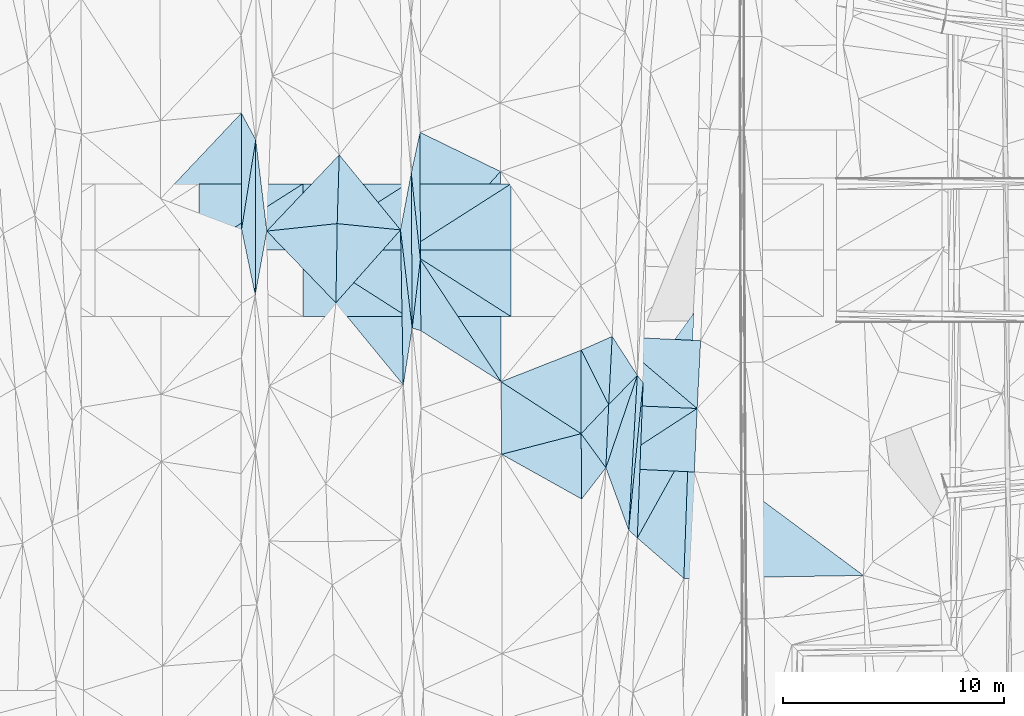
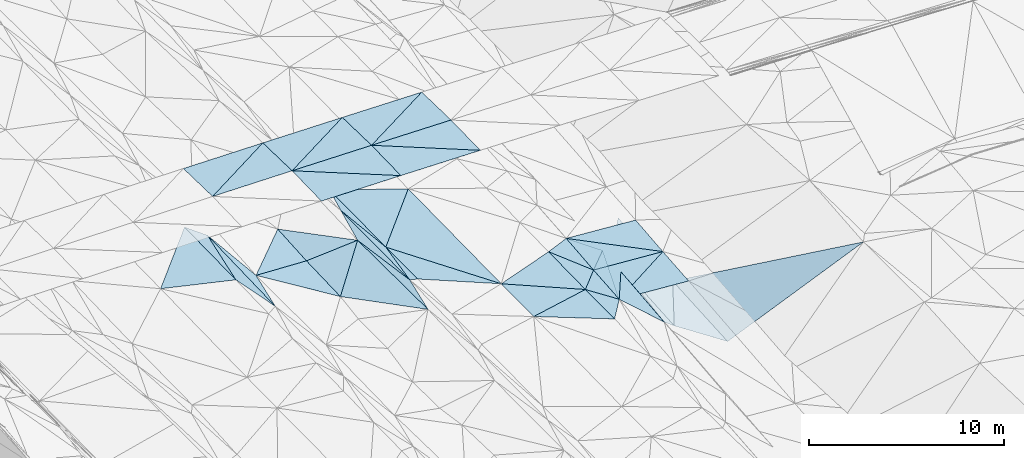
# One storey, part 95 of 275: 47 plates.
"""IFC2X3 building model written with IfcOpenShell, lengths in millimetres."""

from ifc_helpers import new_model, si_unit, frame, origin_with_axes, place, context, subcontext, project, spatial, polyline, outline, extrude, material, type_object, element, save


model = new_model("IFC2X3")

# Units and contexts
model_context = context("Model", 3, precision=1e-05, world=origin_with_axes())
body_context = subcontext(model_context, "Body", "Model", "MODEL_VIEW")
ifc_project = project(units=[si_unit("LENGTHUNIT", "METRE", prefix="MILLI"), si_unit("AREAUNIT", "SQUARE_METRE"), si_unit("VOLUMEUNIT", "CUBIC_METRE"), si_unit("MASSUNIT", "GRAM", prefix="KILO"), si_unit("TIMEUNIT", "SECOND"), si_unit("PLANEANGLEUNIT", "RADIAN"), si_unit("SOLIDANGLEUNIT", "STERADIAN"), si_unit("THERMODYNAMICTEMPERATUREUNIT", "DEGREE_CELSIUS"), si_unit("LUMINOUSINTENSITYUNIT", "LUMEN")], contexts=[model_context])

# Site, building, storey
site_placement = place(None, origin_with_axes())
site = spatial("IfcSite", under=ifc_project, at=site_placement, CompositionType="ELEMENT")
building_placement = place(site_placement, origin_with_axes())
building = spatial("IfcBuilding", under=site, at=building_placement, Name="Undefined", CompositionType="ELEMENT")
storey_placement = place(building_placement, origin_with_axes())
storey = spatial("IfcBuildingStorey", under=building, at=storey_placement, Name="Undefined", CompositionType="ELEMENT", Elevation=0.0)

# Plates
ifc_material = material()
plate_type_1 = type_object("IfcPlateType", PredefinedType="NOTDEFINED")
plate_1_placement = place(storey_placement, frame((-62622.9079218116, 50647.9083197546, 42160.5565771011), z_axis=(-0.460394480321487, 0.0397424290163372, -0.88682436921038), x_axis=(0.0559114934761434, 0.998312090561052, 0.0157122479896816)))
element("IfcPlate", 1, at=plate_1_placement, inside=storey, type_object=plate_type_1, material=ifc_material, Name="00", context=body_context, shape_type="SweptSolid", body=[
    extrude(outline(polyline([(0.0, 0.0), (7000.90771484375, -5.98083715885878e-09), (6675.8369140625, 313.728942871094), (0.0, 0.0)])), frame((-8.85201319254618e-08, 2.18876761149539e-07, -0.5000001331573), z_axis=(0.0, 0.0, 1.0), x_axis=(1.0, 0.0, 0.0)), (0.0, 0.0, 1.0), 1.0),
])
plate_type_2 = type_object("IfcPlateType", PredefinedType="NOTDEFINED")
plate_2_placement = place(storey_placement, frame((-59530.6009066562, 56141.5906830387, 42155.2853825518), z_axis=(-0.0333974991696779, 0.0202650055084432, -0.999236676969453), x_axis=(-0.998434100956353, 0.0442164110268405, 0.0342674049701011)))
element("IfcPlate", 2, at=plate_2_placement, inside=storey, type_object=plate_type_2, material=ifc_material, Name="00_PR", context=body_context, shape_type="SweptSolid", body=[
    extrude(outline(polyline([(0.0, 0.0), (4002.46240234375, -1.37442839331925e-08), (3981.3720703125, 3081.78735351563), (0.0, 0.0)])), frame((-8.85201319254618e-08, 2.18876761149539e-07, -0.5000001331573), z_axis=(0.0, 0.0, 1.0), x_axis=(1.0, 0.0, 0.0)), (0.0, 0.0, 1.0), 1.0),
])
plate_type_3 = type_object("IfcPlateType", PredefinedType="NOTDEFINED")
plate_3_placement = place(storey_placement, frame((-59530.6009117455, 56141.5905549054, 42155.2853799508), z_axis=(-0.0334090181771891, 0.0200086100496844, -0.999241458821798), x_axis=(-0.838485170529092, -0.544655161301775, 0.0171281659886843)))
element("IfcPlate", 3, at=plate_3_placement, inside=storey, type_object=plate_type_3, material=ifc_material, Name="00_PR", context=body_context, shape_type="SweptSolid", body=[
    extrude(outline(polyline([(0.0, 0.0), (4916.75537109375, 1.64582161232829e-08), (3256.70922851563, 2326.70361328125), (0.0, 0.0)])), frame((-8.85201319254618e-08, 2.18876761149539e-07, -0.5000001331573), z_axis=(0.0, 0.0, 1.0), x_axis=(1.0, 0.0, 0.0)), (0.0, 0.0, 1.0), 1.0),
])
plate_type_4 = type_object("IfcPlateType", PredefinedType="NOTDEFINED")
plate_4_placement = place(storey_placement, frame((-63653.2272984867, 53463.6543003292, 42239.5003764176), z_axis=(-0.0333032417168968, 0.0198455561030795, -0.999248241426576), x_axis=(0.838485170530217, 0.544655161299832, -0.0171281659954277)))
element("IfcPlate", 4, at=plate_4_placement, inside=storey, type_object=plate_type_4, material=ifc_material, Name="00_PR", context=body_context, shape_type="SweptSolid", body=[
    extrude(outline(polyline([(0.0, 0.0), (4916.75537109375, 1.64582161232829e-08), (3248.17700195313, 2338.44311523438), (0.0, 0.0)])), frame((-8.85201319254618e-08, 2.18876761149539e-07, -0.5000001331573), z_axis=(0.0, 0.0, 1.0), x_axis=(1.0, 0.0, 0.0)), (0.0, 0.0, 1.0), 1.0),
])
plate_type_5 = type_object("IfcPlateType", PredefinedType="NOTDEFINED")
plate_5_placement = place(storey_placement, frame((-63367.4366551746, 59395.7726568381, 42349.520380845), z_axis=(-0.0331212995075395, 0.0205908088339851, -0.999239209654272), x_axis=(0.99825921601693, -0.0481356620235582, -0.0340807229797011)))
element("IfcPlate", 5, at=plate_5_placement, inside=storey, type_object=plate_type_5, material=ifc_material, Name="00_PR", context=body_context, shape_type="SweptSolid", body=[
    extrude(outline(polyline([(0.0, 0.0), (4002.3505859375, -1.29221007227898e-08), (3993.41870117188, 3066.1611328125), (0.0, 0.0)])), frame((-8.85201319254618e-08, 2.18876761149539e-07, -0.5000001331573), z_axis=(0.0, 0.0, 1.0), x_axis=(1.0, 0.0, 0.0)), (0.0, 0.0, 1.0), 1.0),
])
plate_type_6 = type_object("IfcPlateType", PredefinedType="NOTDEFINED")
plate_6_placement = place(storey_placement, frame((-75846.6448886976, 60913.4388032371, 42160.5063472335), z_axis=(0.158670936192576, 0.00957541698476766, -0.987285088207727), x_axis=(0.0161448274595793, 0.999794111267461, 0.0122914450414822)))
element("IfcPlate", 6, at=plate_6_placement, inside=storey, type_object=plate_type_6, material=ifc_material, Name="00", context=body_context, shape_type="SweptSolid", body=[
    extrude(outline(polyline([(0.0, 0.0), (3579.7255859375, -2.2409949451685e-09), (3345.93896484375, 2901.70947265625), (0.0, 0.0)])), frame((-8.85201319254618e-08, 2.18876761149539e-07, -0.5000001331573), z_axis=(0.0, 0.0, 1.0), x_axis=(1.0, 0.0, 0.0)), (0.0, 0.0, 1.0), 1.0),
])
plate_type_7 = type_object("IfcPlateType", PredefinedType="NOTDEFINED")
plate_7_placement = place(storey_placement, frame((-67930.6135374298, 60290.7959923241, 48911.6592011381), z_axis=(-0.0137950724437344, 0.0249906028113443, -0.999592499845511), x_axis=(-0.99990476257614, 5.73189794360328e-05, 0.0138008149066281)))
element("IfcPlate", 7, at=plate_7_placement, inside=storey, type_object=plate_type_7, material=ifc_material, Name="00_PR", context=body_context, shape_type="SweptSolid", body=[
    extrude(outline(polyline([(0.0, 0.0), (4700.44677734375, 1.99725036509335e-08), (4701.48193359375, 3000.93725585938), (0.0, 0.0)])), frame((-8.85201319254618e-08, 2.18876761149539e-07, -0.5000001331573), z_axis=(0.0, 0.0, 1.0), x_axis=(1.0, 0.0, 0.0)), (0.0, 0.0, 1.0), 1.0),
])
plate_8_placement = place(storey_placement, frame((-72630.6114541768, 60291.0654152484, 48976.5291843486), z_axis=(-0.0111850117114007, 0.0249912679383459, -0.999625095743324), x_axis=(-0.999937389058023, 5.72339822805614e-05, 0.011189936912048)))
element("IfcPlate", 8, at=plate_8_placement, inside=storey, type_object=plate_type_7, material=ifc_material, Name="00_PR", context=body_context, shape_type="SweptSolid", body=[
    extrude(outline(polyline([(0.0, 0.0), (4700.29443359375, -1.01208570413291e-08), (4701.13330078125, 3000.93725585938), (0.0, 0.0)])), frame((-8.85201319254618e-08, 2.18876761149539e-07, -0.5000001331573), z_axis=(0.0, 0.0, 1.0), x_axis=(1.0, 0.0, 0.0)), (0.0, 0.0, 1.0), 1.0),
])
for number, where, z_axis, x_axis, name in (
    (9, (-67930.2697725053, 66290.7710463539, 48911.6592006968), (-0.0137979380693952, -0.0249890218047729, -0.999592499818938), (-5.7277968073799e-05, -0.999687644772795, 0.0249921909375039), "00_PR"),
    (10, (-72630.4408754233, 63291.040446763, 49051.52920014), (-0.0137979380693952, -0.0249890218047729, -0.999592499818938), (5.72779774420735e-05, 0.999687644773175, -0.0249921909222736), "00_PR"),
):
    element("IfcPlate", number, at=place(storey_placement, frame(where, z_axis=z_axis, x_axis=x_axis)), inside=storey, type_object=plate_type_7, material=ifc_material, Name=name, context=body_context, shape_type="SweptSolid", body=[
        extrude(outline(polyline([(0.0, 0.0), (3000.9375, -1.02954800240695e-08), (3002.55859375, 4700.44677734375), (0.0, 0.0)])), frame((-8.85201319254618e-08, 2.18876761149539e-07, -0.5000001331573), z_axis=(0.0, 0.0, 1.0), x_axis=(1.0, 0.0, 0.0)), (0.0, 0.0, 1.0), 1.0),
    ])
for number, where, z_axis, x_axis, name in (
    (11, (-72630.2676887108, 66291.040467875, 48976.5291837821), (-0.0111878728430461, -0.0249899862474312, -0.999625095767709), (-5.7277968073799e-05, -0.999687644772795, 0.0249921909375039), "00_PR"),
    (12, (-77330.4397072677, 63291.3094641183, 49104.1251831819), (-0.0111878728430461, -0.0249899862474312, -0.999625095767709), (5.72779774420735e-05, 0.999687644773175, -0.0249921909222736), "00_PR"),
):
    element("IfcPlate", number, at=place(storey_placement, frame(where, z_axis=z_axis, x_axis=x_axis)), inside=storey, type_object=plate_type_7, material=ifc_material, Name=name, context=body_context, shape_type="SweptSolid", body=[
        extrude(outline(polyline([(0.0, 0.0), (3000.9375, -1.02954800240695e-08), (3002.25219726563, 4700.29443359375), (0.0, 0.0)])), frame((-8.85201319254618e-08, 2.18876761149539e-07, -0.5000001331573), z_axis=(0.0, 0.0, 1.0), x_axis=(1.0, 0.0, 0.0)), (0.0, 0.0, 1.0), 1.0),
    ])
for number, where, z_axis, x_axis, name in (
    (13, (-77330.2665201644, 66291.3094854778, 49029.1251701908), (-0.00857758355597849, -0.0249907804608136, -0.999650882034473), (-5.7277968073799e-05, -0.999687644772795, 0.0249921909375039), "00_PR"),
    (14, (-82030.4385384965, 63291.5784817604, 49144.4471697582), (-0.00857758355597849, -0.0249907804608136, -0.999650882034473), (5.72779774420735e-05, 0.999687644773175, -0.0249921909222736), "00_PR"),
):
    element("IfcPlate", number, at=place(storey_placement, frame(where, z_axis=z_axis, x_axis=x_axis)), inside=storey, type_object=plate_type_7, material=ifc_material, Name=name, context=body_context, shape_type="SweptSolid", body=[
        extrude(outline(polyline([(0.0, 0.0), (3000.9375, -1.02954800240695e-08), (3001.9453125, 4700.1728515625), (0.0, 0.0)])), frame((-8.85201319254618e-08, 2.18876761149539e-07, -0.5000001331573), z_axis=(0.0, 0.0, 1.0), x_axis=(1.0, 0.0, 0.0)), (0.0, 0.0, 1.0), 1.0),
    ])
plate_9_placement = place(storey_placement, frame((-72630.4408734797, 63291.0654365271, 49051.5292003042), z_axis=(-0.0137950724437344, 0.0249906028113443, -0.999592499845511), x_axis=(0.999904762576025, -5.73189663768295e-05, -0.0138008149150225)))
element("IfcPlate", 15, at=plate_9_placement, inside=storey, type_object=plate_type_7, material=ifc_material, Name="00_PR", context=body_context, shape_type="SweptSolid", body=[
    extrude(outline(polyline([(0.0, 0.0), (4700.44677734375, 1.99725036509335e-08), (4701.48193359375, 3000.93725585938), (0.0, 0.0)])), frame((-8.85201319254618e-08, 2.18876761149539e-07, -0.5000001331573), z_axis=(0.0, 0.0, 1.0), x_axis=(1.0, 0.0, 0.0)), (0.0, 0.0, 1.0), 1.0),
])
plate_10_placement = place(storey_placement, frame((-77330.4397046504, 63291.3344552473, 49104.1251836285), z_axis=(-0.0111850117114007, 0.0249912679383459, -0.999625095743324), x_axis=(0.999937389057897, -5.72339667357559e-05, -0.0111899369233562)))
element("IfcPlate", 16, at=plate_10_placement, inside=storey, type_object=plate_type_7, material=ifc_material, Name="00_PR", context=body_context, shape_type="SweptSolid", body=[
    extrude(outline(polyline([(0.0, 0.0), (4700.29443359375, -1.01208570413291e-08), (4701.13330078125, 3000.93725585938), (0.0, 0.0)])), frame((-8.85201319254618e-08, 2.18876761149539e-07, -0.5000001331573), z_axis=(0.0, 0.0, 1.0), x_axis=(1.0, 0.0, 0.0)), (0.0, 0.0, 1.0), 1.0),
])
plate_type_8 = type_object("IfcPlateType", PredefinedType="NOTDEFINED")
plate_11_placement = place(storey_placement, frame((-64771.1542860667, 55003.0855761435, 42309.5005410427), z_axis=(-0.0431627633672693, 0.0185771769478519, -0.998895322020856), x_axis=(-0.838000357288145, 0.543699985436666, 0.0463219928447625)))
element("IfcPlate", 17, at=plate_11_placement, inside=storey, type_object=plate_type_8, material=ifc_material, Name="00", context=body_context, shape_type="SweptSolid", body=[
    extrude(outline(polyline([(0.0, 0.0), (4317.603515625, 4.83669282402843e-09), (2051.53149414063, 3168.51977539063), (0.0, 0.0)])), frame((-8.85201319254618e-08, 2.18876761149539e-07, -0.5000001331573), z_axis=(0.0, 0.0, 1.0), x_axis=(1.0, 0.0, 0.0)), (0.0, 0.0, 1.0), 1.0),
])
plate_type_9 = type_object("IfcPlateType", PredefinedType="NOTDEFINED")
plate_12_placement = place(storey_placement, frame((-79490.4899329426, 61268.4595638201, 42610.5056361018), z_axis=(-0.147382494175674, 0.027199825444776, -0.988705502111893), x_axis=(0.00349889745495088, 0.999629882701583, 0.0269787940171397)))
element("IfcPlate", 18, at=plate_12_placement, inside=storey, type_object=plate_type_9, material=ifc_material, Name="00", context=body_context, shape_type="SweptSolid", body=[
    extrude(outline(polyline([(0.0, 0.0), (7005.50244140625, -1.55705492943525e-08), (2886.90869140625, 521.528259277344), (0.0, 0.0)])), frame((-8.85201319254618e-08, 2.18876761149539e-07, -0.5000001331573), z_axis=(0.0, 0.0, 1.0), x_axis=(1.0, 0.0, 0.0)), (0.0, 0.0, 1.0), 1.0),
])
plate_type_10 = type_object("IfcPlateType", PredefinedType="NOTDEFINED")
plate_13_placement = place(storey_placement, frame((-72031.6819182087, 62869.025692803, 42729.5001079757), z_axis=(-0.0156070395302007, 0.0154378636027901, -0.999759017305913), x_axis=(0.00687675665944684, -0.999855494649088, -0.0155467050487833)))
element("IfcPlate", 19, at=plate_13_placement, inside=storey, type_object=plate_type_10, material=ifc_material, Name="00", context=body_context, shape_type="SweptSolid", body=[
    extrude(outline(polyline([(0.0, 0.0), (3216.11572265625, -1.10740074887872e-08), (3091.31298828125, 390.985015869141), (0.0, 0.0)])), frame((-8.85201319254618e-08, 2.18876761149539e-07, -0.5000001331573), z_axis=(0.0, 0.0, 1.0), x_axis=(1.0, 0.0, 0.0)), (0.0, 0.0, 1.0), 1.0),
])
plate_type_11 = type_object("IfcPlateType", PredefinedType="NOTDEFINED")
plate_14_placement = place(storey_placement, frame((-72401.2466628017, 59775.3775062983, 42687.5096428878), z_axis=(0.194770315823585, 0.0173998689377229, -0.980694533804962), x_axis=(-0.118044347531311, 0.992991232920248, -0.00582609298185243)))
element("IfcPlate", 20, at=plate_14_placement, inside=storey, type_object=plate_type_11, material=ifc_material, Name="00", context=body_context, shape_type="SweptSolid", body=[
    extrude(outline(polyline([(0.0, 0.0), (4462.68212890625, -1.03755155578256e-08), (6953.0888671875, 800.726501464844), (0.0, 0.0)])), frame((-8.85201319254618e-08, 2.18876761149539e-07, -0.5000001331573), z_axis=(0.0, 0.0, 1.0), x_axis=(1.0, 0.0, 0.0)), (0.0, 0.0, 1.0), 1.0),
])
plate_type_12 = type_object("IfcPlateType", PredefinedType="NOTDEFINED")
plate_15_placement = place(storey_placement, frame((-72031.6816379332, 62869.0266525101, 42729.5001210857), z_axis=(-0.0150474886913772, 0.0173653022180142, -0.999735974826834), x_axis=(-0.104610616620881, 0.99433467516252, 0.0188460250356723)))
element("IfcPlate", 21, at=plate_15_placement, inside=storey, type_object=plate_type_12, material=ifc_material, Name="00", context=body_context, shape_type="SweptSolid", body=[
    extrude(outline(polyline([(0.0, 0.0), (3926.5576171875, 3.07045411318541e-09), (5715.68115234375, 587.104248046875), (0.0, 0.0)])), frame((-8.85201319254618e-08, 2.18876761149539e-07, -0.5000001331573), z_axis=(0.0, 0.0, 1.0), x_axis=(1.0, 0.0, 0.0)), (0.0, 0.0, 1.0), 1.0),
])
plate_type_13 = type_object("IfcPlateType", PredefinedType="NOTDEFINED")
plate_16_placement = place(storey_placement, frame((-64771.1502121912, 55003.0862915457, 42309.5003951425), z_axis=(-0.0350156011398439, 0.0200063060505654, -0.999186496803788), x_axis=(0.587201873650538, -0.808605001829176, -0.0367683368965134)))
element("IfcPlate", 22, at=plate_16_placement, inside=storey, type_object=plate_type_13, material=ifc_material, Name="00", context=body_context, shape_type="SweptSolid", body=[
    extrude(outline(polyline([(0.0, 0.0), (1903.81201171875, 3.19050741381943e-09), (2404.01904296875, 1713.85327148438), (0.0, 0.0)])), frame((-8.85201319254618e-08, 2.18876761149539e-07, -0.5000001331573), z_axis=(0.0, 0.0, 1.0), x_axis=(1.0, 0.0, 0.0)), (0.0, 0.0, 1.0), 1.0),
])
plate_type_14 = type_object("IfcPlateType", PredefinedType="NOTDEFINED")
plate_17_placement = place(storey_placement, frame((-59679.6482851019, 60454.356702733, 41700.5155854622), z_axis=(-0.243177618684068, 0.0476838411503677, -0.968809009590793), x_axis=(-0.0398150584993632, -0.998439865171729, -0.0391483939971007)))
element("IfcPlate", 23, at=plate_17_placement, inside=storey, type_object=plate_type_14, material=ifc_material, Name="00", context=body_context, shape_type="SweptSolid", body=[
    extrude(outline(polyline([(0.0, 0.0), (6002.80029296875, -1.07393134385347e-08), (3225.05126953125, 2232.37768554688), (0.0, 0.0)])), frame((-8.85201319254618e-08, 2.18876761149539e-07, -0.5000001331573), z_axis=(0.0, 0.0, 1.0), x_axis=(1.0, 0.0, 0.0)), (0.0, 0.0, 1.0), 1.0),
])
plate_type_15 = type_object("IfcPlateType", PredefinedType="NOTDEFINED")
plate_18_placement = place(storey_placement, frame((-63367.4384019649, 59395.7730744748, 42349.5004349173), z_axis=(-0.0363958953445794, 0.0213656580138624, -0.999109026813241), x_axis=(0.542238394479855, -0.839378358572376, -0.0377027149188569)))
element("IfcPlate", 24, at=plate_18_placement, inside=storey, type_object=plate_type_15, material=ifc_material, Name="00", context=body_context, shape_type="SweptSolid", body=[
    extrude(outline(polyline([(0.0, 0.0), (2095.33984375, -4.32919478043914e-10), (2498.79272460938, 1803.94970703125), (0.0, 0.0)])), frame((-8.85201319254618e-08, 2.18876761149539e-07, -0.5000001331573), z_axis=(0.0, 0.0, 1.0), x_axis=(1.0, 0.0, 0.0)), (0.0, 0.0, 1.0), 1.0),
])
plate_type_16 = type_object("IfcPlateType", PredefinedType="NOTDEFINED")
plate_19_placement = place(storey_placement, frame((-72802.9771938272, 57204.3926323249, 42541.5125751304), z_axis=(0.221989270135014, 0.0206700001852873, -0.974829992889665), x_axis=(-0.01785275654214, 0.99969384410979, 0.0171317580194544)))
element("IfcPlate", 25, at=plate_19_placement, inside=storey, type_object=plate_type_16, material=ifc_material, Name="00", context=body_context, shape_type="SweptSolid", body=[
    extrude(outline(polyline([(0.0, 0.0), (7004.53515625, -1.88883859664202e-08), (2565.5283203125, 459.075256347656), (0.0, 0.0)])), frame((-8.85201319254618e-08, 2.18876761149539e-07, -0.5000001331573), z_axis=(0.0, 0.0, 1.0), x_axis=(1.0, 0.0, 0.0)), (0.0, 0.0, 1.0), 1.0),
])
plate_type_17 = type_object("IfcPlateType", PredefinedType="NOTDEFINED")
plate_20_placement = place(storey_placement, frame((-61971.6454867976, 57299.184895519, 42120.5309234617), z_axis=(-0.345106751450643, 0.0281463794768717, -0.938141306747298), x_axis=(-0.037294237465294, -0.999172061024237, -0.0162583000482977)))
element("IfcPlate", 26, at=plate_20_placement, inside=storey, type_object=plate_type_17, material=ifc_material, Name="00", context=body_context, shape_type="SweptSolid", body=[
    extrude(outline(polyline([(0.0, 0.0), (7011.80322265625, 1.74622982740402e-09), (6669.41162109375, 429.158294677734), (0.0, 0.0)])), frame((-8.85201319254618e-08, 2.18876761149539e-07, -0.5000001331573), z_axis=(0.0, 0.0, 1.0), x_axis=(1.0, 0.0, 0.0)), (0.0, 0.0, 1.0), 1.0),
])
plate_type_18 = type_object("IfcPlateType", PredefinedType="NOTDEFINED")
plate_21_placement = place(storey_placement, frame((-72401.356014939, 59775.3770266252, 42687.5001975702), z_axis=(-0.0239205232229422, 0.0164288214303113, -0.999578862519187), x_axis=(-0.00587075465772763, 0.999845411520414, 0.0165736930502503)))
element("IfcPlate", 27, at=plate_21_placement, inside=storey, type_object=plate_type_18, material=ifc_material, Name="00", context=body_context, shape_type="SweptSolid", body=[
    extrude(outline(polyline([(0.0, 0.0), (6999.04345703125, -2.88127921521664e-09), (3091.69677734375, 387.938232421875), (0.0, 0.0)])), frame((-8.85201319254618e-08, 2.18876761149539e-07, -0.5000001331573), z_axis=(0.0, 0.0, 1.0), x_axis=(1.0, 0.0, 0.0)), (0.0, 0.0, 1.0), 1.0),
])
plate_type_19 = type_object("IfcPlateType", PredefinedType="NOTDEFINED")
plate_22_placement = place(storey_placement, frame((-63653.2277502169, 53463.6539121982, 42239.5003683651), z_axis=(-0.0339964281395568, 0.0190059461796691, -0.999241220568671), x_axis=(0.0442354853571116, 0.998867952652653, 0.0174938560276795)))
element("IfcPlate", 28, at=plate_22_placement, inside=storey, type_object=plate_type_19, material=ifc_material, Name="00", context=body_context, shape_type="SweptSolid", body=[
    extrude(outline(polyline([(0.0, 0.0), (2858.14624023438, 6.37373887002468e-09), (4232.05419921875, 1236.68334960938), (0.0, 0.0)])), frame((-8.85201319254618e-08, 2.18876761149539e-07, -0.5000001331573), z_axis=(0.0, 0.0, 1.0), x_axis=(1.0, 0.0, 0.0)), (0.0, 0.0, 1.0), 1.0),
])
plate_type_20 = type_object("IfcPlateType", PredefinedType="NOTDEFINED")
plate_23_placement = place(storey_placement, frame((-59918.6593941608, 54460.9075605981, 41465.5175185993), z_axis=(-0.26169347948458, 0.0200687794576447, -0.964942364541185), x_axis=(-0.0354461134840764, -0.999309157741182, -0.0111705099920495)))
element("IfcPlate", 29, at=plate_23_placement, inside=storey, type_object=plate_type_20, material=ifc_material, Name="00", context=body_context, shape_type="SweptSolid", body=[
    extrude(outline(polyline([(0.0, 0.0), (5997.935546875, -1.08557287603617e-08), (4240.84033203125, 2243.77709960938), (0.0, 0.0)])), frame((-8.85201319254618e-08, 2.18876761149539e-07, -0.5000001331573), z_axis=(0.0, 0.0, 1.0), x_axis=(1.0, 0.0, 0.0)), (0.0, 0.0, 1.0), 1.0),
])
plate_type_21 = type_object("IfcPlateType", PredefinedType="NOTDEFINED")
plate_24_placement = place(storey_placement, frame((-64745.4726089748, 52051.4188506705, 42249.5005158881), z_axis=(-0.0413461884936113, 0.0199463336519956, -0.998945762527122), x_axis=(-0.87202974718685, 0.487303132383418, 0.0458233258346327)))
element("IfcPlate", 30, at=plate_24_placement, inside=storey, type_object=plate_type_21, material=ifc_material, Name="00", context=body_context, shape_type="SweptSolid", body=[
    extrude(outline(polyline([(0.0, 0.0), (4146.35986328125, 1.89174897968769e-09), (1463.50061035156, 2564.13061523438), (0.0, 0.0)])), frame((-8.85201319254618e-08, 2.18876761149539e-07, -0.5000001331573), z_axis=(0.0, 0.0, 1.0), x_axis=(1.0, 0.0, 0.0)), (0.0, 0.0, 1.0), 1.0),
])
plate_type_22 = type_object("IfcPlateType", PredefinedType="NOTDEFINED")
plate_25_placement = place(storey_placement, frame((-62231.2610870786, 57636.9881661037, 42270.5002804412), z_axis=(-0.029172198229618, 0.0173635604362653, -0.999423578678944), x_axis=(-0.0559114934384432, -0.99831209056263, -0.0157122480236009)))
element("IfcPlate", 31, at=plate_25_placement, inside=storey, type_object=plate_type_22, material=ifc_material, Name="00", context=body_context, shape_type="SweptSolid", body=[
    extrude(outline(polyline([(0.0, 0.0), (7000.90771484375, -5.98083715885878e-09), (4246.2822265625, 1186.91088867188), (0.0, 0.0)])), frame((-8.85201319254618e-08, 2.18876761149539e-07, -0.5000001331573), z_axis=(0.0, 0.0, 1.0), x_axis=(1.0, 0.0, 0.0)), (0.0, 0.0, 1.0), 1.0),
])
plate_type_23 = type_object("IfcPlateType", PredefinedType="NOTDEFINED")
plate_26_placement = place(storey_placement, frame((-80117.0808412147, 69484.6663995802, 42799.5005765171), z_axis=(0.0427589312854142, 0.0229494105004323, -0.998821805104901), x_axis=(0.472907201461201, -0.881112239618844, 4.77451848853747e-11)))
element("IfcPlate", 32, at=plate_26_placement, inside=storey, type_object=plate_type_23, material=ifc_material, Name="00", context=body_context, shape_type="SweptSolid", body=[
    extrude(outline(polyline([(0.0, 0.0), (1377.00903320313, -1.03027559816837e-08), (4625.1328125, 2472.78100585938), (0.0, 0.0)])), frame((-8.85201319254618e-08, 2.18876761149539e-07, -0.5000001331573), z_axis=(0.0, 0.0, 1.0), x_axis=(1.0, 0.0, 0.0)), (0.0, 0.0, 1.0), 1.0),
])
plate_type_24 = type_object("IfcPlateType", PredefinedType="NOTDEFINED")
plate_27_placement = place(storey_placement, frame((-80106.0650992171, 64241.3890257361, 42679.5002485684), z_axis=(0.0179372712237755, 0.026911879714935, -0.999476865680869), x_axis=(0.156816884358768, 0.987190141765395, 0.0293953870739732)))
element("IfcPlate", 33, at=plate_27_placement, inside=storey, type_object=plate_type_24, material=ifc_material, Name="00", context=body_context, shape_type="SweptSolid", body=[
    extrude(outline(polyline([(0.0, 0.0), (4082.27319335938, -1.53231667354703e-08), (-2840.32958984375, 1074.5390625), (0.0, 0.0)])), frame((-8.85201319254618e-08, 2.18876761149539e-07, -0.5000001331573), z_axis=(0.0, 0.0, 1.0), x_axis=(1.0, 0.0, 0.0)), (0.0, 0.0, 1.0), 1.0),
])
plate_type_25 = type_object("IfcPlateType", PredefinedType="NOTDEFINED")
plate_28_placement = place(storey_placement, frame((-72928.0646237415, 64206.7828538884, 42661.5055678756), z_axis=(0.147646827162525, 0.0195825731297867, -0.988846265735203), x_axis=(0.0178527565330552, -0.999693844109806, -0.0171317580280003)))
element("IfcPlate", 34, at=plate_28_placement, inside=storey, type_object=plate_type_25, material=ifc_material, Name="00", context=body_context, shape_type="SweptSolid", body=[
    extrude(outline(polyline([(0.0, 0.0), (7004.53515625, -1.88883859664202e-08), (3248.80908203125, 3010.06079101563), (0.0, 0.0)])), frame((-8.85201319254618e-08, 2.18876761149539e-07, -0.5000001331573), z_axis=(0.0, 0.0, 1.0), x_axis=(1.0, 0.0, 0.0)), (0.0, 0.0, 1.0), 1.0),
])
plate_type_26 = type_object("IfcPlateType", PredefinedType="NOTDEFINED")
plate_29_placement = place(storey_placement, frame((-63526.7973926132, 56318.5646578337, 42289.5004086664), z_axis=(-0.0362556648434038, 0.0191045739580185, -0.999159918141558), x_axis=(-0.0442354853595046, -0.998867952652762, -0.0174938560154424)))
element("IfcPlate", 35, at=plate_29_placement, inside=storey, type_object=plate_type_26, material=ifc_material, Name="00", context=body_context, shape_type="SweptSolid", body=[
    extrude(outline(polyline([(0.0, 0.0), (2858.14624023438, 6.37373887002468e-09), (1368.68432617188, 1185.75), (0.0, 0.0)])), frame((-8.85201319254618e-08, 2.18876761149539e-07, -0.5000001331573), z_axis=(0.0, 0.0, 1.0), x_axis=(1.0, 0.0, 0.0)), (0.0, 0.0, 1.0), 1.0),
])
plate_type_27 = type_object("IfcPlateType", PredefinedType="NOTDEFINED")
plate_30_placement = place(storey_placement, frame((-72031.6891910759, 62869.0279436722, 42729.5003141287), z_axis=(-0.0301510851582539, 0.0199393040720135, -0.999346454547623), x_axis=(0.673644526398879, 0.739034456320116, -0.00557892681983447)))
element("IfcPlate", 36, at=plate_30_placement, inside=storey, type_object=plate_type_27, material=ifc_material, Name="00", context=body_context, shape_type="SweptSolid", body=[
    extrude(outline(polyline([(0.0, 0.0), (5377.37841796875, 2.88127921521664e-09), (-1623.43041992188, 6413.52294921875), (0.0, 0.0)])), frame((-8.85201319254618e-08, 2.18876761149539e-07, -0.5000001331573), z_axis=(0.0, 0.0, 1.0), x_axis=(1.0, 0.0, 0.0)), (0.0, 0.0, 1.0), 1.0),
])
plate_type_28 = type_object("IfcPlateType", PredefinedType="NOTDEFINED")
plate_31_placement = place(storey_placement, frame((-63367.4355735818, 59395.7729310006, 42349.5003363387), z_axis=(-0.0307415374525682, 0.0210766594959491, -0.999305124723948), x_axis=(-0.0517078063763755, -0.99847247512189, -0.0194684150281791)))
element("IfcPlate", 37, at=plate_31_placement, inside=storey, type_object=plate_type_28, material=ifc_material, Name="00", context=body_context, shape_type="SweptSolid", body=[
    extrude(outline(polyline([(0.0, 0.0), (3081.9150390625, 7.8580342233181e-09), (689.473937988281, 1366.171875), (0.0, 0.0)])), frame((-8.85201319254618e-08, 2.18876761149539e-07, -0.5000001331573), z_axis=(0.0, 0.0, 1.0), x_axis=(1.0, 0.0, 0.0)), (0.0, 0.0, 1.0), 1.0),
])
plate_type_29 = type_object("IfcPlateType", PredefinedType="NOTDEFINED")
plate_32_placement = place(storey_placement, frame((-64771.1535099585, 55003.086773185, 42309.5005318404), z_axis=(-0.0416107536189993, 0.0209708511388438, -0.998913794371552), x_axis=(-0.967378270533757, -0.250902767520076, 0.0350297437884325)))
element("IfcPlate", 38, at=plate_32_placement, inside=storey, type_object=plate_type_29, material=ifc_material, Name="00", context=body_context, shape_type="SweptSolid", body=[
    extrude(outline(polyline([(0.0, 0.0), (3711.1318359375, -1.20344338938594e-08), (2918.13940429688, 3182.16333007813), (0.0, 0.0)])), frame((-8.85201319254618e-08, 2.18876761149539e-07, -0.5000001331573), z_axis=(0.0, 0.0, 1.0), x_axis=(1.0, 0.0, 0.0)), (0.0, 0.0, 1.0), 1.0),
])
plate_type_30 = type_object("IfcPlateType", PredefinedType="NOTDEFINED")
plate_33_placement = place(storey_placement, frame((-68389.3045934718, 57350.5648899714, 42509.5003921805), z_axis=(-0.0372000641747459, 0.0152805197610081, -0.999191003232729), x_axis=(-0.843105460308827, 0.536288900406575, 0.0395903788583504)))
element("IfcPlate", 39, at=plate_33_placement, inside=storey, type_object=plate_type_30, material=ifc_material, Name="00", context=body_context, shape_type="SweptSolid", body=[
    extrude(outline(polyline([(0.0, 0.0), (4293.97265625, 6.98491930961609e-09), (6039.1162109375, 2701.45751953125), (0.0, 0.0)])), frame((-8.85201319254618e-08, 2.18876761149539e-07, -0.5000001331573), z_axis=(0.0, 0.0, 1.0), x_axis=(1.0, 0.0, 0.0)), (0.0, 0.0, 1.0), 1.0),
])
plate_type_31 = type_object("IfcPlateType", PredefinedType="NOTDEFINED")
plate_34_placement = place(storey_placement, frame((-80117.0828915872, 69484.6664036102, 42799.5004916745), z_axis=(0.0386660095624904, 0.0229446217297062, -0.998988730686285), x_axis=(0.00210273763407738, -0.999735998090642, -0.022880398076754)))
element("IfcPlate", 40, at=plate_34_placement, inside=storey, type_object=plate_type_31, material=ifc_material, Name="00", context=body_context, shape_type="SweptSolid", body=[
    extrude(outline(polyline([(0.0, 0.0), (5244.6640625, -2.04163370653987e-08), (3861.9443359375, 3659.49267578125), (0.0, 0.0)])), frame((-8.85201319254618e-08, 2.18876761149539e-07, -0.5000001331573), z_axis=(0.0, 0.0, 1.0), x_axis=(1.0, 0.0, 0.0)), (0.0, 0.0, 1.0), 1.0),
])
plate_type_32 = type_object("IfcPlateType", PredefinedType="NOTDEFINED")
plate_35_placement = place(storey_placement, frame((-64766.7870128457, 58777.125975296, 42379.5003949207), z_axis=(-0.0356952589122033, 0.0185740104616083, -0.999190099343745), x_axis=(0.45008188653328, -0.892389561716882, -0.0326674999563105)))
element("IfcPlate", 41, at=plate_35_placement, inside=storey, type_object=plate_type_32, material=ifc_material, Name="00", context=body_context, shape_type="SweptSolid", body=[
    extrude(outline(polyline([(0.0, 0.0), (2755.03173828125, -7.87622411735356e-09), (3368.23706054688, 1703.90124511719), (0.0, 0.0)])), frame((-8.85201319254618e-08, 2.18876761149539e-07, -0.5000001331573), z_axis=(0.0, 0.0, 1.0), x_axis=(1.0, 0.0, 0.0)), (0.0, 0.0, 1.0), 1.0),
])
plate_type_33 = type_object("IfcPlateType", PredefinedType="NOTDEFINED")
plate_36_placement = place(storey_placement, frame((-68409.2461312931, 66843.0946647987, 42699.5002524991), z_axis=(-0.0272903943459441, 0.0173307399933928, -0.999477303307946), x_axis=(-0.673644526484159, -0.739034456242108, 0.00557892685606193)))
element("IfcPlate", 42, at=plate_36_placement, inside=storey, type_object=plate_type_33, material=ifc_material, Name="00", context=body_context, shape_type="SweptSolid", body=[
    extrude(outline(polyline([(0.0, 0.0), (5377.37841796875, 2.88127921521664e-09), (1141.78308105469, 3882.45166015625), (0.0, 0.0)])), frame((-8.85201319254618e-08, 2.18876761149539e-07, -0.5000001331573), z_axis=(0.0, 0.0, 1.0), x_axis=(1.0, 0.0, 0.0)), (0.0, 0.0, 1.0), 1.0),
])
plate_type_34 = type_object("IfcPlateType", PredefinedType="NOTDEFINED")
plate_37_placement = place(storey_placement, frame((-61971.6085972896, 57299.1837139643, 42120.5189234057), z_axis=(-0.271328823736077, 0.0257831310205803, -0.962141309561528), x_axis=(0.576083672182664, -0.796457477305024, -0.183801766828981)))
element("IfcPlate", 43, at=plate_37_placement, inside=storey, type_object=plate_type_34, material=ifc_material, Name="00", context=body_context, shape_type="SweptSolid", body=[
    extrude(outline(polyline([(0.0, 0.0), (3563.62182617188, 7.93079379945993e-10), (5450.287109375, 4411.3212890625), (0.0, 0.0)])), frame((-8.85201319254618e-08, 2.18876761149539e-07, -0.5000001331573), z_axis=(0.0, 0.0, 1.0), x_axis=(1.0, 0.0, 0.0)), (0.0, 0.0, 1.0), 1.0),
])
plate_type_35 = type_object("IfcPlateType", PredefinedType="NOTDEFINED")
plate_38_placement = place(storey_placement, frame((-78964.5498556068, 64154.5629159465, 42611.5041930237), z_axis=(-0.128607055302878, 0.0142673871100727, -0.991592994626008), x_axis=(0.986408785113038, 0.104950105558269, -0.126424617836592)))
element("IfcPlate", 44, at=plate_38_placement, inside=storey, type_object=plate_type_35, material=ifc_material, Name="00", context=body_context, shape_type="SweptSolid", body=[
    extrude(outline(polyline([(0.0, 0.0), (3219.30981445313, 2.18278728425503e-08), (2792.24853515625, 3554.16015625), (0.0, 0.0)])), frame((-8.85201319254618e-08, 2.18876761149539e-07, -0.5000001331573), z_axis=(0.0, 0.0, 1.0), x_axis=(1.0, 0.0, 0.0)), (0.0, 0.0, 1.0), 1.0),
])
plate_type_36 = type_object("IfcPlateType", PredefinedType="NOTDEFINED")
plate_39_placement = place(storey_placement, frame((-75695.5835643495, 67595.1562781242, 42274.5043960135), z_axis=(-0.129832252040289, 0.0262708101516234, -0.991187888779985), x_axis=(-0.030085046454752, -0.999293058915723, -0.0225448970428381)))
element("IfcPlate", 45, at=plate_39_placement, inside=storey, type_object=plate_type_36, material=ifc_material, Name="00", context=body_context, shape_type="SweptSolid", body=[
    extrude(outline(polyline([(0.0, 0.0), (3104.91552734375, 1.47701939567924e-08), (3528.90454101563, 3191.267578125), (0.0, 0.0)])), frame((-8.85201319254618e-08, 2.18876761149539e-07, -0.5000001331573), z_axis=(0.0, 0.0, 1.0), x_axis=(1.0, 0.0, 0.0)), (0.0, 0.0, 1.0), 1.0),
])
plate_type_37 = type_object("IfcPlateType", PredefinedType="NOTDEFINED")
plate_40_placement = place(storey_placement, frame((-60130.9434454517, 48467.1042451633, 41398.5369317488), z_axis=(0.377214568949308, -0.00302763875780949, -0.926120943708726), x_axis=(0.0354461134363272, 0.999309157742777, 0.0111705100009596)))
element("IfcPlate", 46, at=plate_40_placement, inside=storey, type_object=plate_type_37, material=ifc_material, Name="00", context=body_context, shape_type="SweptSolid", body=[
    extrude(outline(polyline([(0.0, 0.0), (5997.935546875, -1.08557287603617e-08), (458.128479003906, 8746.27734375), (0.0, 0.0)])), frame((-8.85201319254618e-08, 2.18876761149539e-07, -0.5000001331573), z_axis=(0.0, 0.0, 1.0), x_axis=(1.0, 0.0, 0.0)), (0.0, 0.0, 1.0), 1.0),
])
plate_type_38 = type_object("IfcPlateType", PredefinedType="NOTDEFINED")
plate_41_placement = place(storey_placement, frame((-72928.0587478711, 64206.7818032455, 42661.5064609836), z_axis=(0.159422510708786, 0.0174691888420733, -0.98705587000965), x_axis=(-0.982714361195688, 0.0981238794761848, -0.156984676246742)))
element("IfcPlate", 47, at=plate_41_placement, inside=storey, type_object=plate_type_38, material=ifc_material, Name="00", context=body_context, shape_type="SweptSolid", body=[
    extrude(outline(polyline([(0.0, 0.0), (2911.11206054688, -1.30312400870025e-08), (3112.77734375, 3098.359375), (0.0, 0.0)])), frame((-8.85201319254618e-08, 2.18876761149539e-07, -0.5000001331573), z_axis=(0.0, 0.0, 1.0), x_axis=(1.0, 0.0, 0.0)), (0.0, 0.0, 1.0), 1.0),
])

save(model, "model.ifc")
